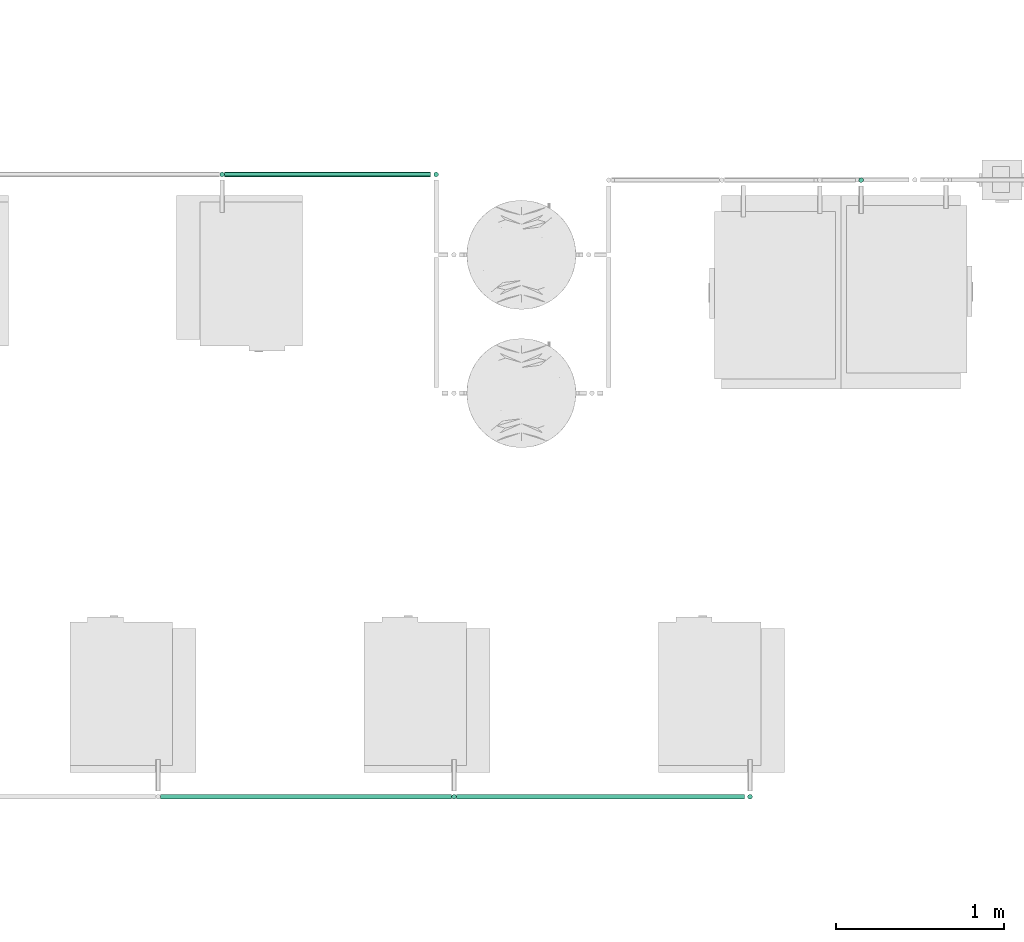
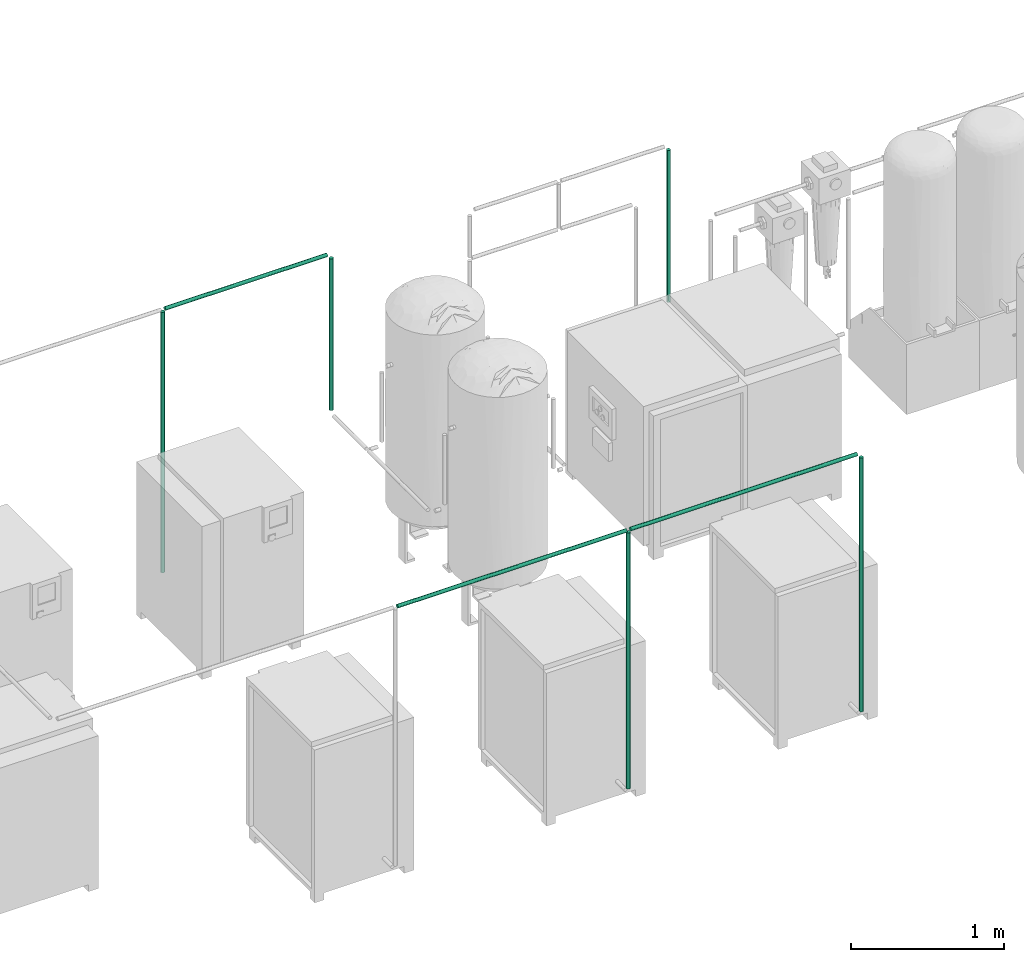
# One storey, part 41 of 331: 8 flow segments.
"""IFC2X3 building model written with IfcOpenShell, lengths in millimetres."""

from ifc_helpers import new_model, entity, si_unit, converted_unit, derived_unit, direction, frame, origin, origin_2d_with_axis, place, context, subcontext, project, spatial, circle, extrude, type_object, element, save


model = new_model("IFC2X3")

# Units and contexts
model_context = context("Model", 3, precision=0.01, world=origin(), true_north=direction((6.12303176911189e-17, 1.0)))
body_context = subcontext(model_context, "Body", "Model", "MODEL_VIEW")
ifc_project = project(units=[si_unit("LENGTHUNIT", "METRE", prefix="MILLI"), si_unit("AREAUNIT", "SQUARE_METRE"), si_unit("VOLUMEUNIT", "CUBIC_METRE"), converted_unit("PLANEANGLEUNIT", "DEGREE", entity("IfcRatioMeasure", 0.0174532925199433), si_unit("PLANEANGLEUNIT", "RADIAN"), dimensions=[0, 0, 0, 0, 0, 0, 0]), si_unit("MASSUNIT", "GRAM", prefix="KILO"), derived_unit("MASSDENSITYUNIT", [(si_unit("MASSUNIT", "GRAM", prefix="KILO"), 1), (si_unit("LENGTHUNIT", "METRE"), -3)]), derived_unit("MOMENTOFINERTIAUNIT", [(si_unit("LENGTHUNIT", "METRE"), 4)]), si_unit("TIMEUNIT", "SECOND"), si_unit("FREQUENCYUNIT", "HERTZ"), si_unit("THERMODYNAMICTEMPERATUREUNIT", "DEGREE_CELSIUS"), derived_unit("THERMALTRANSMITTANCEUNIT", [(si_unit("MASSUNIT", "GRAM", prefix="KILO"), 1), (si_unit("THERMODYNAMICTEMPERATUREUNIT", "KELVIN"), -1), (si_unit("TIMEUNIT", "SECOND"), -3)]), derived_unit("VOLUMETRICFLOWRATEUNIT", [(si_unit("LENGTHUNIT", "METRE"), 3), (si_unit("TIMEUNIT", "SECOND"), -1)]), derived_unit("MASSFLOWRATEUNIT", [(si_unit("MASSUNIT", "GRAM", prefix="KILO"), 1), (si_unit("TIMEUNIT", "SECOND"), -1)]), derived_unit("ROTATIONALFREQUENCYUNIT", [(si_unit("TIMEUNIT", "SECOND"), -1)]), si_unit("ELECTRICCURRENTUNIT", "AMPERE"), si_unit("ELECTRICVOLTAGEUNIT", "VOLT"), si_unit("POWERUNIT", "WATT"), si_unit("FORCEUNIT", "NEWTON", prefix="KILO"), si_unit("ILLUMINANCEUNIT", "LUX"), si_unit("LUMINOUSFLUXUNIT", "LUMEN"), si_unit("LUMINOUSINTENSITYUNIT", "CANDELA"), derived_unit("USERDEFINED", [(si_unit("MASSUNIT", "GRAM", prefix="KILO"), -1), (si_unit("LENGTHUNIT", "METRE"), -2), (si_unit("TIMEUNIT", "SECOND"), 3), (si_unit("LUMINOUSFLUXUNIT", "LUMEN"), 1)]), derived_unit("LINEARVELOCITYUNIT", [(si_unit("LENGTHUNIT", "METRE"), 1), (si_unit("TIMEUNIT", "SECOND"), -1)]), si_unit("PRESSUREUNIT", "PASCAL"), derived_unit("USERDEFINED", [(si_unit("LENGTHUNIT", "METRE"), -2), (si_unit("MASSUNIT", "GRAM", prefix="KILO"), 1), (si_unit("TIMEUNIT", "SECOND"), -2)]), derived_unit("LINEARFORCEUNIT", [(si_unit("MASSUNIT", "GRAM", prefix="KILO"), 1), (si_unit("LENGTHUNIT", "METRE"), 1), (si_unit("TIMEUNIT", "SECOND"), -2), (si_unit("LENGTHUNIT", "METRE"), -1)]), derived_unit("PLANARFORCEUNIT", [(si_unit("MASSUNIT", "GRAM", prefix="KILO"), 1), (si_unit("LENGTHUNIT", "METRE"), 1), (si_unit("TIMEUNIT", "SECOND"), -2), (si_unit("LENGTHUNIT", "METRE"), -2)])], contexts=[model_context])

# Site, building, storey
site_placement = place(None, frame((0.0, -0.00077364408347762, 0.0)))
site = spatial("IfcSite", under=ifc_project, at=site_placement, CompositionType="ELEMENT")
building_placement = place(site_placement, origin())
building = spatial("IfcBuilding", under=site, at=building_placement, CompositionType="ELEMENT")
storey_placement = place(building_placement, origin())
storey = spatial("IfcBuildingStorey", under=building, at=storey_placement, CompositionType="ELEMENT", Elevation=0.0)

# Flow segments
pipe_segment_type = type_object("IfcPipeSegmentType", PredefinedType="NOTDEFINED")
flow_segment_1_placement = place(storey_placement, frame((50094.7467312679, -4370.59537393443, 1551.93082503605)))
element("IfcFlowSegment", 1, at=flow_segment_1_placement, inside=storey, type_object=pipe_segment_type, context=body_context, shape_type="SweptSolid", body=[
    extrude(circle(Radius=14.0, at=origin_2d_with_axis()), frame((0.0, 15.5952722359203, 15.595272235916), z_axis=(1.0, 0.0, 0.0), x_axis=(0.0, -1.0, 0.0)), (0.0, 0.0, 1.0), 1711.0438308246),
])
flow_segment_2_placement = place(storey_placement, frame((48715.7079557027, -670.59537393444, 1551.93082503605)))
element("IfcFlowSegment", 2, at=flow_segment_2_placement, inside=storey, type_object=pipe_segment_type, context=body_context, shape_type="SweptSolid", body=[
    extrude(circle(Radius=14.0, at=origin_2d_with_axis()), frame((0.0, 15.5952722359161, 15.595272235916), z_axis=(1.0, 0.0, 0.0), x_axis=(0.0, -1.0, 0.0)), (0.0, 0.0, 1.0), 1223.86231606795),
])
flow_segment_3_placement = place(storey_placement, frame((48685.1126834668, -670.59537393444, -528.473902728048)))
element("IfcFlowSegment", 3, at=flow_segment_3_placement, inside=storey, type_object=pipe_segment_type, context=body_context, shape_type="SweptSolid", body=[
    extrude(circle(Radius=14.0, at=origin_2d_with_axis()), frame((15.5952722359127, 15.5952722359161, 0.0)), (0.0, 0.0, 1.0), 2081.00000000002),
])
flow_segment_4_placement = place(storey_placement, frame((50064.1514590499, -4370.59537393443, -493.474606472981)))
element("IfcFlowSegment", 4, at=flow_segment_4_placement, inside=storey, type_object=pipe_segment_type, context=body_context, shape_type="SweptSolid", body=[
    extrude(circle(Radius=14.0, at=origin_2d_with_axis()), frame((15.6986033868607, 15.595272235916, 0.000707055896291564), z_axis=(-5.05039925935638e-05, 0.0, 1.0), x_axis=(-1.0, 0.0, -5.05039925935638e-05)), (0.0, 0.0, 1.0), 2045.99999929837),
])
flow_segment_5_placement = place(storey_placement, frame((51824.1952898566, -4370.59537393443, -493.473902728048)))
element("IfcFlowSegment", 5, at=flow_segment_5_placement, inside=storey, type_object=pipe_segment_type, context=body_context, shape_type="SweptSolid", body=[
    extrude(circle(Radius=14.0, at=origin_2d_with_axis()), frame((15.5952722359127, 15.595272235916, 0.0)), (0.0, 0.0, 1.0), 2027.00000000002),
])
flow_segment_6_placement = place(storey_placement, frame((48334.7905620925, -4370.59537393443, 1551.93082503605)))
element("IfcFlowSegment", 6, at=flow_segment_6_placement, inside=storey, type_object=pipe_segment_type, context=body_context, shape_type="SweptSolid", body=[
    extrude(circle(Radius=14.0, at=origin_2d_with_axis()), frame((0.0, 15.5952722359181, 15.595272235916), z_axis=(1.0, 0.0, 0.0), x_axis=(0.0, -1.0, 0.0)), (0.0, 0.0, 1.0), 1729.9561691754),
])
flow_segment_7_placement = place(building_placement, frame((52484.5036812108, -703.940912916258, 321.526097271962)))
element("IfcFlowSegment", 7, at=flow_segment_7_placement, inside=storey, type_object=pipe_segment_type, context=body_context, shape_type="SweptSolid", body=[
    extrude(circle(Radius=14.0, at=origin_2d_with_axis()), frame((15.5952722359127, 15.5952722359161, 0.0)), (0.0, 0.0, 1.0), 1212.00000000001),
])
flow_segment_8_placement = place(storey_placement, frame((49957.9749995348, -670.595373934434, 321.526097271964)))
element("IfcFlowSegment", 8, at=flow_segment_8_placement, inside=storey, type_object=pipe_segment_type, context=body_context, shape_type="SweptSolid", body=[
    extrude(circle(Radius=14.0, at=origin_2d_with_axis()), frame((15.5952722359127, 15.5952722359161, 0.0)), (0.0, 0.0, 1.0), 1212.00000000001),
])

save(model, "model.ifc")
